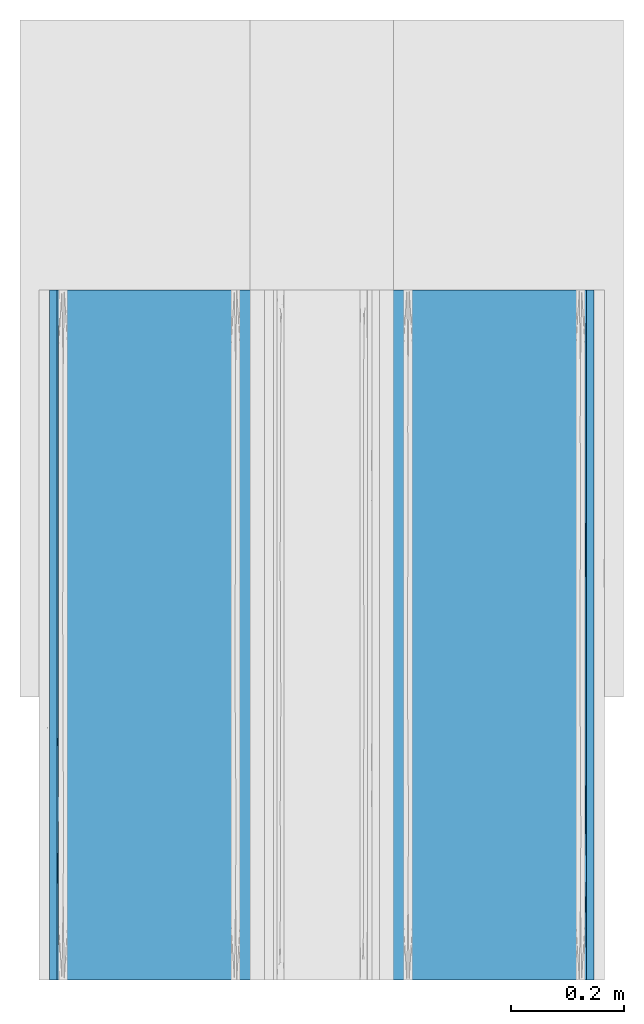
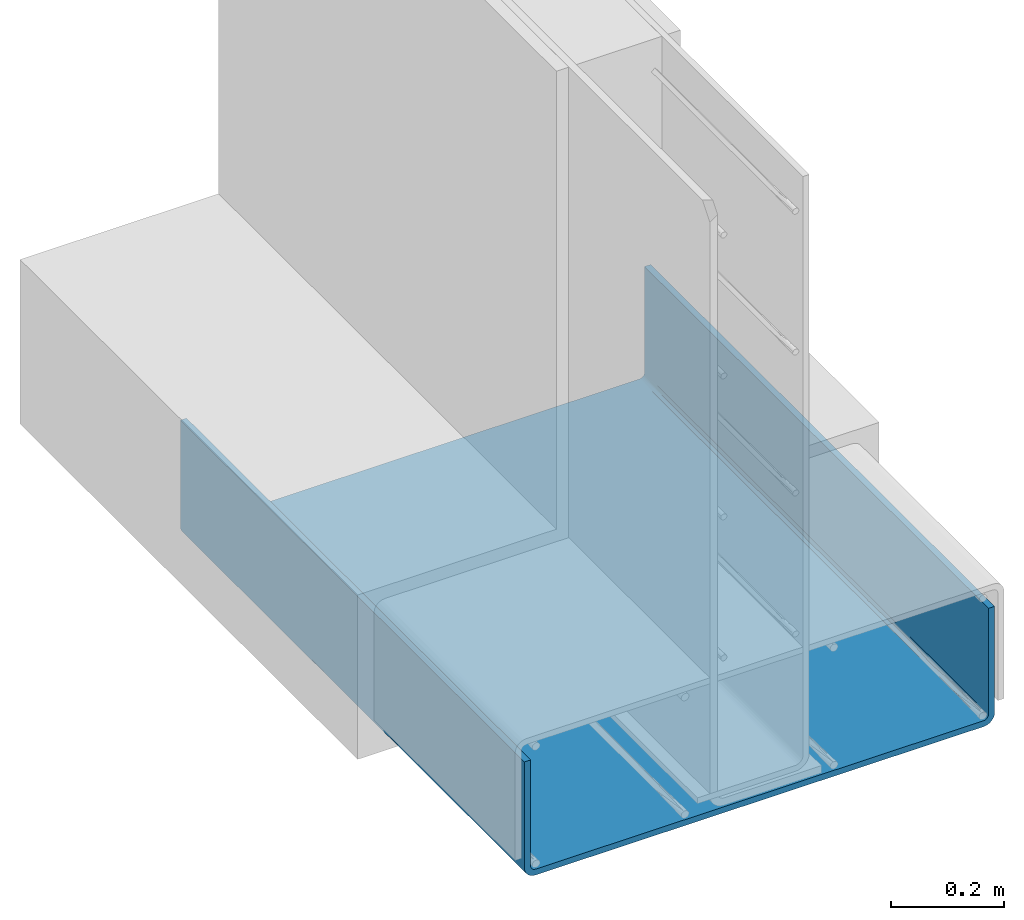
# One storey, part 4 of 10: 1 wall.
"""IFC2X3 building model written with IfcOpenShell, lengths in feet."""

from ifc_helpers import new_model, entity, si_unit, converted_unit, derived_unit, direction, frame, origin, place, context, subcontext, project, spatial, faceted_brep, material, type_object, element, save


model = new_model("IFC2X3")

# Units and contexts
model_context = context("Model", 3, precision=0.0001, world=origin(), true_north=direction((6.12303176911189e-17, 1.0)))
body_context = subcontext(model_context, "Body", "Model", "MODEL_VIEW")
ifc_project = project(units=[converted_unit("LENGTHUNIT", "FOOT", entity("IfcRatioMeasure", 0.3048), si_unit("LENGTHUNIT", "METRE"), dimensions=[1, 0, 0, 0, 0, 0, 0]), converted_unit("AREAUNIT", "SQUARE FOOT", entity("IfcRatioMeasure", 0.09290304), si_unit("AREAUNIT", "SQUARE_METRE"), dimensions=[2, 0, 0, 0, 0, 0, 0]), converted_unit("VOLUMEUNIT", "CUBIC FOOT", entity("IfcRatioMeasure", 0.028316846592), si_unit("VOLUMEUNIT", "CUBIC_METRE"), dimensions=[3, 0, 0, 0, 0, 0, 0]), converted_unit("PLANEANGLEUNIT", "DEGREE", entity("IfcRatioMeasure", 0.0174532925199433), si_unit("PLANEANGLEUNIT", "RADIAN"), dimensions=[0, 0, 0, 0, 0, 0, 0]), si_unit("MASSUNIT", "GRAM", prefix="KILO"), derived_unit("MASSDENSITYUNIT", [(si_unit("MASSUNIT", "GRAM", prefix="KILO"), 1), (si_unit("LENGTHUNIT", "METRE"), -3)]), si_unit("TIMEUNIT", "SECOND"), si_unit("FREQUENCYUNIT", "HERTZ"), si_unit("THERMODYNAMICTEMPERATUREUNIT", "DEGREE_CELSIUS"), derived_unit("THERMALTRANSMITTANCEUNIT", [(si_unit("MASSUNIT", "GRAM", prefix="KILO"), 1), (si_unit("THERMODYNAMICTEMPERATUREUNIT", "KELVIN"), -1), (si_unit("TIMEUNIT", "SECOND"), -3)]), derived_unit("VOLUMETRICFLOWRATEUNIT", [(si_unit("LENGTHUNIT", "METRE"), 3), (si_unit("TIMEUNIT", "SECOND"), -1)]), si_unit("ELECTRICCURRENTUNIT", "AMPERE"), si_unit("ELECTRICVOLTAGEUNIT", "VOLT"), si_unit("POWERUNIT", "WATT"), si_unit("FORCEUNIT", "NEWTON", prefix="KILO"), si_unit("ILLUMINANCEUNIT", "LUX"), si_unit("LUMINOUSFLUXUNIT", "LUMEN"), si_unit("LUMINOUSINTENSITYUNIT", "CANDELA"), derived_unit("USERDEFINED", [(si_unit("MASSUNIT", "GRAM", prefix="KILO"), -1), (si_unit("LENGTHUNIT", "METRE"), -2), (si_unit("TIMEUNIT", "SECOND"), 3), (si_unit("LUMINOUSFLUXUNIT", "LUMEN"), 1)]), derived_unit("LINEARVELOCITYUNIT", [(si_unit("LENGTHUNIT", "METRE"), 1), (si_unit("TIMEUNIT", "SECOND"), -1)]), si_unit("PRESSUREUNIT", "PASCAL"), derived_unit("USERDEFINED", [(si_unit("LENGTHUNIT", "METRE"), -2), (si_unit("MASSUNIT", "GRAM", prefix="KILO"), 1), (si_unit("TIMEUNIT", "SECOND"), -2)])], contexts=[model_context])

# Site, building, storey
site_placement = place(None, origin())
site = spatial("IfcSite", under=ifc_project, at=site_placement, CompositionType="ELEMENT")
building_placement = place(site_placement, origin())
building = spatial("IfcBuilding", under=site, at=building_placement, CompositionType="ELEMENT")
storey_placement = place(building_placement, frame((0.0, 0.0, 11.2604166666667)))
storey = spatial("IfcBuildingStorey", under=building, at=storey_placement, Name="2ND FLOOR", CompositionType="ELEMENT", Elevation=11.2604166666667)

# Wall
ifc_material = material()
wall_type = type_object("IfcWallType", Name="Generic Models 1", PredefinedType="NOTDEFINED", material=ifc_material)
wall_placement = place(storey_placement, frame((1428.10066369988, 0.249999999995844, 2.82690841074834), z_axis=(0.0, 0.0, 1.0), x_axis=(0.0, 1.0, 0.0)))
element("IfcWall", 1, at=wall_placement, inside=storey, type_object=wall_type, material=ifc_material, Name="Generic Models 51:Generic Models 1", ObjectType="Generic Models 51:Generic Models 1", context=body_context, shape_type="Brep", body=[
    faceted_brep([(4.0, 0.0, 0.828124999998936), (4.0, -0.0416666666667425, 0.828124999998936), (4.0, -0.0416666666665151, 0.0742261927187702), (4.0, -0.0427761056132567, 0.0657991672769764), (4.0, -0.0460288160224991, 0.0579464296927217), (4.0, -0.0512031310549901, 0.0512031310551127), (4.0, -0.0579464296927199, 0.0460288160224742), (4.0, -0.065799167276964, 0.0427761056133189), (4.0, -0.0742261927186973, 0.0416666666666732), (4.0, -3.08202380728176, 0.0416666666666732), (4.0, -3.09045083272349, 0.0427761056133189), (4.0, -3.09830357030773, 0.0460288160224742), (4.0, -3.10504686894546, 0.0512031310551127), (4.0, -3.11022118397796, 0.0579464296927217), (4.0, -3.1134738943872, 0.0657991672769764), (4.0, -3.11458333333394, 0.0742261927187702), (4.0, -3.11458333333371, 0.828124999998936), (4.0, -3.15625000000045, 0.828124999998936), (4.0, -3.15625000000045, 0.0742261927187702), (4.0, -3.15372080381599, 0.0550150403977039), (4.0, -3.14630557580244, 0.0371130963593878), (4.0, -3.13450965149491, 0.0217403485056735), (4.0, -3.11913690364122, 0.00994442419812103), (4.0, -3.10123495960283, 0.00252919618460723), (4.0, -3.08202380728176, 0.0), (4.0, -0.0742261927186973, 0.0), (4.0, -0.0550150403976204, 0.00252919618460723), (4.0, -0.037113096359235, 0.0099444241981228), (4.0, -0.0217403485055456, 0.0217403485056735), (4.0, -0.00994442419801089, 0.0371130963593895), (4.0, -0.00252919618446867, 0.0550150403977039), (4.0, 0.0, 0.0742261927187702), (0.0, -3.15625000000045, 0.828124999998943), (0.0, -3.11458333333371, 0.828124999998943), (0.0, -3.11458333333394, 0.0742261927187773), (0.0, -3.1134738943872, 0.0657991672769835), (0.0, -3.11022118397796, 0.0579464296927288), (0.0, -3.10504686894546, 0.0512031310551198), (0.0, -3.09830357030773, 0.0460288160224813), (0.0, -3.09045083272349, 0.042776105613326), (0.0, -3.08202380728176, 0.041666666664943), (0.0, -0.0742261927186973, 0.0416666666666803), (0.0, -0.065799167276964, 0.042776105613326), (0.0, -0.0579464296927199, 0.0460288160224813), (0.0, -0.0512031310549901, 0.0512031310551198), (0.0, -0.0460288160224991, 0.0579464296927288), (0.0, -0.0427761056132567, 0.0657991672769835), (0.0, -0.0416666666667425, 0.0742261927187773), (0.0, -0.0416666666667425, 0.828124999998943), (0.0, 0.0, 0.828124999998943), (0.0, 0.0, 0.0742261927187773), (0.0, -0.00252919618446867, 0.055015040397711), (0.0, -0.00994442419801089, 0.0371130963593966), (0.0, -0.0217403485055456, 0.0217403485056806), (0.0, -0.037113096359235, 0.00994442419812991), (0.0, -0.0550150403976204, 0.00252919618461434), (0.0, -0.0742261927186973, 0.0), (0.0, -3.08202380728176, 0.0), (0.0, -3.10123495960283, 0.00252919618461434), (0.0, -3.11913690364122, 0.00994442419812813), (0.0, -3.13450965149491, 0.0217403485056806), (0.0, -3.14630557580244, 0.0371130963593949), (0.0, -3.15372080381599, 0.055015040397711), (0.0, -3.15625000000045, 0.0742261927187773), (0.180442581603972, -3.08202380728176, 0.0416666666666661), (0.500000038873015, -3.08202380728176, 0.0416666666666679), (0.750000006478844, -3.08202380728198, 0.0416666666666679), (0.999999974084673, -3.08202380728176, 0.0416666666666679), (1.25000004535185, -3.08202380728176, 0.0416666666666679), (1.50000001295768, -3.08202380728176, 0.0416666666666696), (1.74999998056351, -3.08202380728176, 0.0416666666666679), (2.00000005183068, -3.08202380728198, 0.0416666666666714), (2.31955750909973, -3.08202380728153, 0.0416666666666696), (2.63911486270742, -3.08202380728176, 0.0416666666666714), (2.95867221631512, -3.08202380728153, 0.0416666666666714), (3.11845094494964, -3.08202380728176, 0.0416666666666714), (3.27822967358416, -3.08202380728176, 0.0416666666666714), (3.45867225518812, -3.08202380728176, 0.0416666666666714), (3.63911483679209, -3.08202380728176, 0.0416666666666732), (3.81955741839605, -3.08202380728176, 0.041666666666675), (3.81955740038467, -0.0742261927186973, 0.0416666666666732), (3.63911480076935, -0.0742261927186973, 0.0416666666666714), (3.36088523640946, -0.0742261927189247, 0.0416666666666714), (3.04132770589895, -0.07422619271847, 0.0416666666666714), (2.72177032410368, -0.0742261927186973, 0.0416666666666696), (2.40221294230841, -0.0742261927186973, 0.0416666666666714), (2.24243417705316, -0.0742261927186973, 0.0416666666666714), (2.0826554117979, -0.0742261927186973, 0.0416666666666696), (1.76309803000263, -0.0742261927189247, 0.0416666666666714), (1.44354064820736, -0.0742261927186973, 0.0416666666666679), (1.26309804859204, -0.0742261927189247, 0.0416666666666679), (1.08265544897671, -0.0742261927186973, 0.0416666666666679), (0.902212849361386, -0.0742261927186973, 0.0416666666666679), (0.72177024974606, -0.07422619271847, 0.0416666666666661), (0.541327650130734, -0.0742261927186973, 0.0416666666666679), (0.360885050515408, -0.0742261927186973, 0.0416666666666679), (0.180442599615326, -0.0742261927186973, 0.0416666666666661), (0.544885964172222, -0.0742261927186973, 0.0), (1.08977192834444, -0.0742261927186973, 0.0), (1.63466914142692, -0.0742261927186973, 0.0), (2.17955510559915, -0.0742261927186973, 0.0), (2.9102168227453, -0.0742261927186973, 0.0), (3.45510278691752, -0.0742261927186973, 0.0), (3.45511214892862, -3.08202380728176, 0.0), (2.91022025791023, -3.08202380728176, 0.0), (2.36532836689184, -3.08202380728176, 0.0), (1.82044051582044, -3.08202380728198, 0.0), (1.08977974208979, -3.08202380728198, 0.0), (0.544887851071403, -3.08202380728176, 0.0), (3.52166542074619, -3.1158921924557, 0.00817727015959946), (3.16735852451752, -3.11042894148841, 0.005650132491958), (3.55697232197401, -3.10325743755152, 0.0031019308168716), (3.44244832472415, -3.12720985043461, 0.015338594790876), (2.30981632325271, -3.15483416152529, 0.0597977485736561), (2.10986574904956, -3.1510530742587, 0.0469408855710807), (2.54488968762932, -3.15126571972087, 0.0474851148181887), (2.99234246861251, -3.15083923805059, 0.0464059811159032), (3.18266546767635, -3.15485446027265, 0.059900562874283), (2.7478200555649, -3.15493287403478, 0.0603051413680156), (3.62777765200876, -3.14091140521396, 0.0290401495717063), (0.557551674741634, -3.14091140522896, 0.0290401495911556), (0.832641474299415, -3.15059986752499, 0.045821058551665), (0.47833457824197, -3.14807272985377, 0.0403578075700235), (3.18266546729614, -3.09500264025155, 0.00114351638389465), (0.489688549903192, -3.12720985045212, 0.0153385948044118), (1.22348175454254, -3.12720985048122, 0.0153385948267442), (3.16200306365107, -3.14091140521509, 0.0290401495732233), (1.77511095543652, -3.12075717366565, 0.0109075223750228), (2.47859294286616, -3.12720985043484, 0.015338594791162), (1.8510373494731, -3.13656471461354, 0.0238792254520401), (1.45511031190419, -3.10494424275089, 0.00362745814488896), (2.7629307082689, -3.11689576012782, 0.00870158214970296), (2.23413872827808, -3.10457174633098, 0.00350760866791155), (2.73095051623614, -3.10234971902082, 0.00283722300008193), (0.707855703412803, -3.11042894152138, 0.00565013250563418), (0.392495591046824, -3.09571476536166, 0.00127356869208484), (2.96052063381757, -3.12980887152708, 0.0174272902593948), (0.443027677445541, -3.15314806919287, 0.0529925624795133), (3.45511404559603, -3.15625000000045, 0.0742261927187702), (3.60739017718949, -3.15497571976698, 0.06053144371573), (1.16662977173362, -3.14191779592056, 0.0303828601533276), (1.0897793149673, -3.15625000000045, 0.0742261927187755), (0.817334531745253, -3.1551064836226, 0.0612473597825716), (1.29274499421643, -3.15472890255705, 0.0592763831371705), (1.84145037480215, -3.09740749899493, 0.00161166445616523), (3.44067317135559, -3.15059986751226, 0.0458210585209802), (2.17955862993459, -3.15625000000045, 0.0742261927187737), (0.817334532997685, -3.09524156694806, 0.00118635074927909), (1.06530183630386, -3.10535619602524, 0.00376253314135333), (2.74179266914021, -3.13888746619477, 0.0265182061699711), (0.544893360563322, -3.15625000000045, 0.0742261927187773), (1.68555575699554, -3.15222374886707, 0.0501119668981662), (1.63466526937128, -3.15625000000045, 0.0742261927187737), (2.91022068503272, -3.15625000000045, 0.0742261927187737), (1.27517456629523, -3.15009031253408, 0.0446208123248528), (2.34763943656025, -3.14255455416628, 0.0312662536227357), (1.80883755086043, -3.1458926524615, 0.0364069079434106), (3.81955741860841, -3.11458333333394, 0.074226192718772), (3.63911483721681, -3.11458333333394, 0.0742261927187702), (3.3608851180604, -3.11458333333394, 0.074226192718772), (3.04132758764498, -3.11458333333394, 0.074226192718772), (2.72177023612079, -3.11458333333394, 0.074226192718772), (2.4022128845966, -3.11458333333394, 0.0742261927187737), (2.24243420883451, -3.11458333333394, 0.074226192718772), (2.08265553307242, -3.11458333333394, 0.0742261927187737), (1.76309818154823, -3.11458333333394, 0.0742261927187755), (1.4435406511328, -3.11458333333394, 0.0742261927187755), (1.26309806974121, -3.11458333333394, 0.0742261927187755), (1.08265548834961, -3.11458333333394, 0.0742261927187773), (0.902212906958007, -3.11458333333394, 0.0742261927187755), (0.721770325566407, -3.11458333333394, 0.0742261927187755), (0.541327744174808, -3.11458333333394, 0.0742261927187755), (0.360885162783209, -3.11458333333394, 0.0742261927187755), (0.180442581391609, -3.11458333333394, 0.0742261927187755), (0.27066387612262, -3.10504686897002, 0.0512031310797934), (1.6760211384918, -3.10533309584275, 0.0514929614588038), (1.37499998996736, -3.10350758163554, 0.0497604988546776), (0.469298945829221, -3.10647469266041, 0.0527255661945141), (1.17539910943218, -3.10545766385781, 0.0516213900717855), (0.993778653964614, -3.10717167052007, 0.0535450972138776), (0.811991627580785, -3.10562603470817, 0.051797247196351), (1.87499998658833, -3.10461931401846, 0.050783372665526), (2.62746326244928, -3.10621111435307, 0.0524294747690455), (2.8201762796202, -3.10371426269558, 0.0499435470498462), (3.72933611283074, -3.1050468684175, 0.0512031305272043), (0.63929646544769, -3.1006032781263, 0.0474880925642953), (3.50074415467746, -3.10504686809713, 0.0512031302068685), (3.31407359801765, -3.10517031378708, 0.0513272413600028), (2.06289507969412, -3.10455494788039, 0.0507215029725643), (2.32232355416369, -3.10590061098583, 0.0520897751762863), (3.03856157936274, -3.10416022507297, 0.0503493892452429), (0.270663875967355, -0.0512031310765906, 0.0512031310335992), (1.67602113862118, -0.0514929614241737, 0.0509169041914461), (1.3749999895459, -0.0497604988252078, 0.0527424183985552), (0.180442567980962, -0.0416666666665151, 0.0742261927187773), (0.469298945513954, -0.0527255661745585, 0.0497753073574874), (3.81955732479936, -0.0416666666665151, 0.0742261927187702), (1.25000002010369, -0.0416666666665151, 0.0742261927187755), (1.1753991094027, -0.0516213900534694, 0.0507923361603613), (1.74999989948155, -0.0416666666665151, 0.0742261927187755), (1.87499998597024, -0.0507833726228455, 0.0516306860263942), (1.99999994639016, -0.0416666666665151, 0.0742261927187737), (0.999999973195081, -0.0416666666665151, 0.0742261927187755), (2.63911478362332, -0.0416666666665151, 0.074226192718772), (2.6274632631305, -0.0524294747099248, 0.0500388857007845), (2.82017627891884, -0.0499435470760545, 0.0525357372756545), (3.72933611259507, -0.0512031303760523, 0.0512031317340345), (3.03856157748759, -0.0503493892408642, 0.0520897749322167), (0.499999986597541, -0.0416666666665151, 0.0742261927187773), (0.639296465193055, -0.047488092564663, 0.0556467218735985), (0.749999926286472, -0.0416666666665151, 0.0742261927187755), (3.50074415373241, -0.0512031300804665, 0.0512031320297588), (3.45867218883744, -0.0416666666665151, 0.0742261927187702), (3.31407359807174, -0.0513272412865717, 0.0510796862860214), (3.6391147568184, -0.0416666666667425, 0.0742261927187702), (2.31955736500674, -0.0416666666665151, 0.0742261927187737), (2.06289507835156, -0.0507215029495001, 0.0516950521440886), (2.32232355337971, -0.0520897751450775, 0.0503493890435074), (0.993778653870263, -0.0535450971437967, 0.0490783295380268), (0.81199162741403, -0.0517972471741359, 0.050623965313445), (2.9586722022399, -0.0416666666665151, 0.074226192718772), (1.49999995979262, -0.0416666666665151, 0.0742261927187755), (3.27822962085648, -0.0416666666665151, 0.074226192718772), (3.11845085793835, -0.0416666666665151, 0.074226192718772), (3.45511457329386, 0.0, 0.0742261927187702), (2.91022222529835, 0.0, 0.074226192718772), (2.36532987730284, 0.0, 0.0742261927187737), (1.8204444505967, 0.0, 0.0742261927187755), (1.08977777470165, 0.0, 0.0742261927187755), (0.544892347995509, 0.0, 0.0742261927187773), (3.52166542093049, -0.0081772701587397, 0.0403578075462168), (3.16735852497786, -0.00565013249092772, 0.0458210585145746), (3.55697232224889, -0.00310193081668331, 0.0529925624496279), (3.4424483250272, -0.0153385947896822, 0.0290401495674111), (2.30981632376837, -0.0597977485815591, 0.00141583847363691), (2.10986574916036, -0.0469408855872189, 0.00519692573538144), (2.54488968757732, -0.0474851148123889, 0.00498428028176257), (2.99234246870888, -0.0464059811076822, 0.00541076195331591), (3.18266546808836, -0.059900562872599, 0.00139553972817552), (2.74782005596114, -0.0603051413595495, 0.00131712596724576), (3.62777765216722, -0.0290401495706192, 0.015338594787206), (0.557551674661815, -0.0290401495833521, 0.0153385947775231), (0.832641474288158, -0.0458210585397865, 0.0056501324804934), (0.47833457842255, -0.0403578075620317, 0.0081772701506857), (3.1826654678637, -0.00114351638308108, 0.0612473597531853), (0.489688549779827, -0.0153385947983224, 0.0290401495560921), (1.22348175499128, -0.0153385948124196, 0.0290401495377388), (3.16200306403048, -0.0290401495715287, 0.0153385947864919), (1.77511095633881, -0.0109075223606396, 0.0354928263583769), (2.47859294360779, -0.0153385947899096, 0.029040149567189), (1.85103734978387, -0.0238792254494911, 0.0196852853893361), (1.45511031216024, -0.00362745813526999, 0.0513057572789624), (2.76293070885072, -0.00870158214684125, 0.0393542398781168), (2.23413872796369, -0.00350760867331701, 0.0516782536522022), (2.7309505162482, -0.00283722299832334, 0.0539002809858911), (0.707855703554035, -0.00565013249956792, 0.0458210584937824), (0.392495590752608, -0.00127356869052164, 0.060535234646359), (2.96052063433155, -0.0174272902554549, 0.0264411284779005), (0.443027677394571, -0.052992562468944, 0.00310193081089238), (3.60739017738584, -0.0605314437143534, 0.00127428023367138), (1.16662977149615, -0.0303828601352052, 0.0143322040930567), (0.817334531552498, -0.0612473597743701, 0.00114351637940757), (1.29274499419333, -0.0592763831266439, 0.00152109744557016), (1.84145037526766, -0.00161166445445815, 0.0588425010138653), (3.44067317160737, -0.0458210585195502, 0.00565013248885116), (0.817334532369706, -0.00118635074659323, 0.0610084330673768), (1.06530183645961, -0.00376253313083907, 0.0508938040069538), (2.7417926689386, -0.0265182061759788, 0.0173625338006875), (1.6855557569572, -0.0501119668720094, 0.00402625114233146), (1.27517456621134, -0.0446208123123597, 0.00615968747188944), (2.34763943584666, -0.0312662536364314, 0.0136954458245437), (1.80883755227699, -0.0364069079375895, 0.0103573475423051)], [[[0, 1, 2, 3, 4, 5, 6, 7, 8, 9, 10, 11, 12, 13, 14, 15, 16, 17, 18, 19, 20, 21, 22, 23, 24, 25, 26, 27, 28, 29, 30, 31]], [[32, 33, 34, 35, 36, 37, 38, 39, 40, 41, 42, 43, 44, 45, 46, 47, 48, 49, 50, 51, 52, 53, 54, 55, 56, 57, 58, 59, 60, 61, 62, 63]], [[40, 64, 65, 66, 67, 68, 69, 70, 71, 72, 73, 74, 75, 76, 77, 78, 79, 9, 8, 80, 81, 82, 83, 84, 85, 86, 87, 88, 89, 90, 91, 92, 93, 94, 95, 96, 41]], [[57, 56, 97, 98, 99, 100, 101, 102, 25, 24, 103, 104, 105, 106, 107, 108]], [[109, 110, 111]], [[112, 22, 21]], [[113, 114, 115]], [[116, 117, 118]], [[21, 20, 119]], [[110, 109, 112]], [[120, 121, 122]], [[103, 123, 104]], [[124, 125, 120]], [[112, 119, 126]], [[127, 128, 129]], [[130, 107, 106]], [[131, 132, 133]], [[58, 134, 59]], [[57, 108, 135]], [[123, 111, 110]], [[136, 131, 110]], [[137, 122, 121]], [[125, 127, 129]], [[18, 138, 139]], [[125, 129, 140]], [[124, 120, 60]], [[141, 142, 143]], [[130, 106, 144]], [[145, 126, 119]], [[120, 61, 60]], [[142, 137, 121]], [[145, 20, 19]], [[146, 113, 118]], [[108, 147, 135]], [[134, 147, 148]], [[115, 118, 113]], [[149, 116, 115]], [[60, 59, 124]], [[140, 120, 125]], [[119, 112, 21]], [[131, 136, 128]], [[138, 117, 139]], [[116, 145, 117]], [[150, 142, 141]], [[63, 62, 137]], [[24, 23, 111]], [[107, 147, 108]], [[148, 125, 134]], [[144, 106, 105]], [[104, 123, 133]], [[59, 134, 124]], [[125, 124, 134]], [[151, 152, 143]], [[153, 117, 138]], [[140, 121, 120]], [[130, 127, 125]], [[143, 154, 151]], [[114, 155, 115]], [[140, 129, 156]], [[118, 117, 153]], [[139, 145, 19]], [[149, 115, 155]], [[126, 145, 116]], [[146, 118, 153]], [[116, 118, 115]], [[150, 137, 142]], [[114, 113, 151]], [[151, 156, 114]], [[114, 156, 155]], [[129, 128, 155]], [[128, 136, 149]], [[156, 151, 154]], [[155, 156, 129]], [[148, 107, 130]], [[135, 134, 58]], [[134, 135, 147]], [[57, 135, 58]], [[145, 139, 117]], [[18, 139, 19]], [[150, 63, 137]], [[121, 154, 143]], [[121, 143, 142]], [[146, 152, 113]], [[151, 113, 152]], [[152, 141, 143]], [[61, 137, 62]], [[121, 140, 154]], [[156, 154, 140]], [[137, 61, 122]], [[61, 120, 122]], [[103, 24, 111]], [[133, 123, 110]], [[131, 133, 110]], [[132, 105, 133]], [[103, 111, 123]], [[22, 111, 23]], [[136, 110, 112]], [[132, 131, 128]], [[112, 126, 136]], [[149, 136, 126]], [[111, 22, 109]], [[22, 112, 109]], [[116, 149, 126]], [[128, 149, 155]], [[145, 119, 20]], [[107, 148, 147]], [[125, 148, 130]], [[144, 127, 130]], [[128, 127, 132]], [[104, 133, 105]], [[127, 144, 132]], [[144, 105, 132]], [[32, 63, 150, 141, 152, 146, 153, 138, 18, 17]], [[33, 32, 17, 16]], [[49, 48, 1, 0]], [[33, 16, 15, 157, 158, 159, 160, 161, 162, 163, 164, 165, 166, 167, 168, 169, 170, 171, 172, 173, 34]], [[172, 174, 173]], [[166, 175, 176]], [[38, 64, 39]], [[174, 172, 177]], [[176, 68, 178]], [[35, 173, 36]], [[179, 180, 169]], [[178, 68, 67]], [[70, 181, 71]], [[73, 182, 183]], [[34, 173, 35]], [[157, 15, 14]], [[11, 184, 12]], [[37, 174, 38]], [[14, 13, 157]], [[64, 40, 39]], [[64, 38, 174]], [[13, 184, 157]], [[65, 185, 66]], [[186, 77, 187]], [[12, 184, 13]], [[36, 174, 37]], [[9, 79, 10]], [[186, 184, 78]], [[72, 188, 189]], [[190, 183, 160]], [[158, 157, 184]], [[181, 165, 164]], [[10, 79, 11]], [[36, 173, 174]], [[79, 184, 11]], [[174, 65, 64]], [[65, 174, 177]], [[158, 184, 186]], [[78, 184, 79]], [[186, 159, 158]], [[187, 159, 186]], [[185, 180, 66]], [[177, 171, 185]], [[190, 74, 183]], [[176, 69, 68]], [[67, 179, 178]], [[160, 187, 190]], [[164, 188, 181]], [[73, 72, 182]], [[185, 171, 170]], [[169, 180, 170]], [[66, 180, 67]], [[180, 185, 170]], [[177, 172, 171]], [[177, 185, 65]], [[187, 160, 159]], [[76, 75, 187, 77]], [[75, 190, 187]], [[190, 75, 74]], [[161, 160, 183]], [[161, 183, 182]], [[183, 74, 73]], [[182, 162, 161]], [[189, 162, 182]], [[181, 70, 175]], [[188, 71, 181]], [[165, 181, 175]], [[165, 175, 166]], [[175, 70, 69]], [[188, 72, 71]], [[164, 163, 188]], [[163, 189, 188]], [[189, 163, 162]], [[72, 189, 182]], [[186, 78, 77]], [[69, 176, 175]], [[178, 167, 176]], [[168, 179, 169]], [[179, 168, 178]], [[166, 176, 167]], [[178, 168, 167]], [[180, 179, 67]], [[95, 191, 96]], [[89, 192, 193]], [[45, 194, 46]], [[191, 95, 195]], [[194, 47, 46]], [[2, 196, 3]], [[42, 96, 43]], [[193, 197, 198]], [[199, 200, 201]], [[198, 197, 202]], [[203, 204, 205]], [[41, 96, 42]], [[80, 8, 7]], [[4, 206, 5]], [[44, 191, 45]], [[207, 205, 83]], [[7, 6, 80]], [[194, 45, 191]], [[6, 206, 80]], [[208, 209, 210]], [[211, 212, 213]], [[5, 206, 6]], [[43, 191, 44]], [[211, 206, 214]], [[215, 216, 217]], [[218, 219, 92]], [[81, 80, 206]], [[200, 88, 87]], [[3, 196, 4]], [[43, 96, 191]], [[196, 206, 4]], [[191, 208, 194]], [[208, 191, 195]], [[81, 206, 211]], [[214, 206, 196]], [[211, 82, 81]], [[213, 82, 211]], [[209, 219, 210]], [[195, 94, 209]], [[207, 220, 205]], [[193, 221, 197]], [[202, 218, 198]], [[83, 213, 207]], [[87, 216, 200]], [[203, 215, 204]], [[209, 94, 93]], [[92, 219, 93]], [[210, 219, 202]], [[219, 209, 93]], [[195, 95, 94]], [[195, 209, 208]], [[213, 83, 82]], [[222, 223, 213, 212]], [[223, 207, 213]], [[207, 223, 220]], [[84, 83, 205]], [[84, 205, 204]], [[205, 220, 203]], [[204, 85, 84]], [[217, 85, 204]], [[200, 199, 192]], [[216, 201, 200]], [[88, 200, 192]], [[88, 192, 89]], [[192, 199, 221]], [[216, 215, 201]], [[87, 86, 216]], [[86, 217, 216]], [[217, 86, 85]], [[215, 217, 204]], [[211, 214, 212]], [[221, 193, 192]], [[198, 90, 193]], [[91, 218, 92]], [[218, 91, 198]], [[89, 193, 90]], [[198, 91, 90]], [[219, 218, 202]], [[48, 47, 194, 208, 210, 202, 197, 221, 199, 201, 215, 203, 220, 223, 222, 212, 214, 196, 2, 1]], [[50, 49, 0, 31, 224, 225, 226, 227, 228, 229]], [[230, 231, 232]], [[233, 29, 28]], [[234, 235, 236]], [[237, 238, 239]], [[28, 27, 240]], [[231, 230, 233]], [[241, 242, 243]], [[224, 244, 225]], [[245, 246, 241]], [[233, 240, 247]], [[248, 249, 250]], [[251, 228, 227]], [[252, 253, 254]], [[51, 255, 52]], [[50, 229, 256]], [[244, 232, 231]], [[257, 252, 231]], [[258, 243, 242]], [[246, 248, 250]], [[25, 102, 259]], [[246, 250, 260]], [[245, 241, 53]], [[98, 261, 262]], [[251, 227, 263]], [[264, 247, 240]], [[241, 54, 53]], [[261, 258, 242]], [[264, 27, 26]], [[100, 234, 239]], [[229, 265, 256]], [[255, 265, 266]], [[236, 239, 234]], [[267, 237, 236]], [[53, 52, 245]], [[260, 241, 246]], [[240, 233, 28]], [[252, 257, 249]], [[102, 238, 259]], [[237, 264, 238]], [[97, 261, 98]], [[56, 55, 258]], [[31, 30, 232]], [[228, 265, 229]], [[266, 246, 255]], [[263, 227, 226]], [[225, 244, 254]], [[52, 255, 245]], [[246, 245, 255]], [[268, 99, 262]], [[101, 238, 102]], [[260, 242, 241]], [[251, 248, 246]], [[262, 269, 268]], [[235, 270, 236]], [[260, 250, 271]], [[239, 238, 101]], [[259, 264, 26]], [[267, 236, 270]], [[247, 264, 237]], [[100, 239, 101]], [[237, 239, 236]], [[97, 258, 261]], [[235, 234, 268]], [[268, 271, 235]], [[235, 271, 270]], [[250, 249, 270]], [[249, 257, 267]], [[271, 268, 269]], [[270, 271, 250]], [[266, 228, 251]], [[256, 255, 51]], [[255, 256, 265]], [[50, 256, 51]], [[264, 259, 238]], [[25, 259, 26]], [[97, 56, 258]], [[242, 269, 262]], [[242, 262, 261]], [[100, 99, 234]], [[268, 234, 99]], [[99, 98, 262]], [[54, 258, 55]], [[242, 260, 269]], [[271, 269, 260]], [[258, 54, 243]], [[54, 241, 243]], [[224, 31, 232]], [[254, 244, 231]], [[252, 254, 231]], [[253, 226, 254]], [[224, 232, 244]], [[29, 232, 30]], [[257, 231, 233]], [[253, 252, 249]], [[233, 247, 257]], [[267, 257, 247]], [[232, 29, 230]], [[29, 233, 230]], [[237, 267, 247]], [[249, 267, 270]], [[264, 240, 27]], [[228, 266, 265]], [[246, 266, 251]], [[263, 248, 251]], [[249, 248, 253]], [[225, 254, 226]], [[248, 263, 253]], [[263, 226, 253]]]),
])

save(model, "model.ifc")
